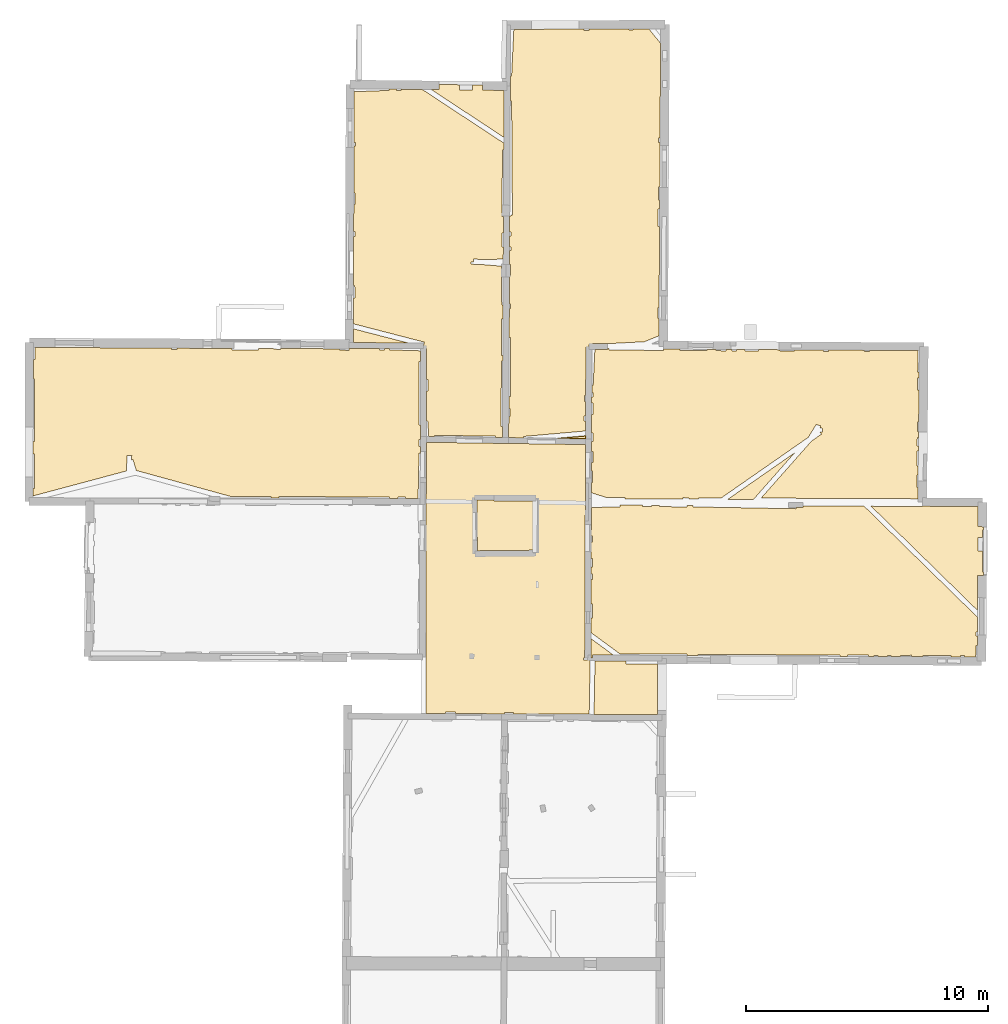
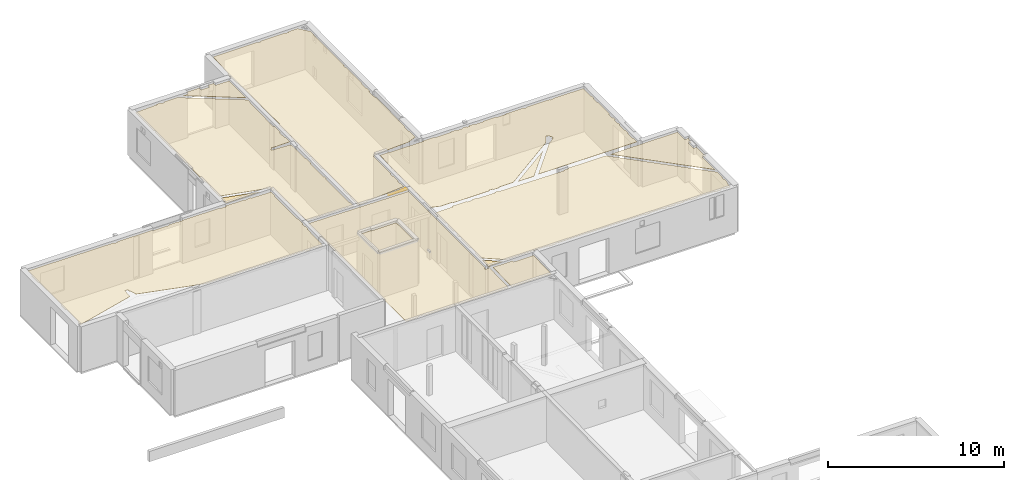
# One storey, part 13 of 17: 14 coverings.
"""IFC2X3 building model written with IfcOpenShell, lengths in metres."""

from ifc_helpers import new_model, entity, si_unit, converted_unit, derived_unit, direction, frame, origin, origin_with_axes, place, context, subcontext, project, spatial, polyline, outline, extrude, material, layer, layer_set, layer_usage, type_object, element, save


model = new_model("IFC2X3")

# Units and contexts
model_context = context("Model", 3, precision=1e-05, world=origin(), true_north=direction((0.0, 1.0)))
body_context = subcontext(model_context, "Body", "Model", "MODEL_VIEW")
ifc_project = project(units=[si_unit("LENGTHUNIT", "METRE"), si_unit("AREAUNIT", "SQUARE_METRE"), si_unit("VOLUMEUNIT", "CUBIC_METRE"), converted_unit("PLANEANGLEUNIT", "DEGREE", entity("IfcRatioMeasure", 0.0174532925199433), si_unit("PLANEANGLEUNIT", "RADIAN"), dimensions=[0, 0, 0, 0, 0, 0, 0]), si_unit("MASSUNIT", "GRAM", prefix="KILO"), derived_unit("MASSDENSITYUNIT", [(si_unit("MASSUNIT", "GRAM", prefix="KILO"), 1), (si_unit("LENGTHUNIT", "METRE"), -3)]), derived_unit("MOMENTOFINERTIAUNIT", [(si_unit("LENGTHUNIT", "METRE"), 4)]), si_unit("TIMEUNIT", "SECOND"), si_unit("FREQUENCYUNIT", "HERTZ"), si_unit("THERMODYNAMICTEMPERATUREUNIT", "DEGREE_CELSIUS"), derived_unit("THERMALTRANSMITTANCEUNIT", [(si_unit("MASSUNIT", "GRAM", prefix="KILO"), 1), (si_unit("THERMODYNAMICTEMPERATUREUNIT", "KELVIN"), -1), (si_unit("TIMEUNIT", "SECOND"), -3)]), derived_unit("VOLUMETRICFLOWRATEUNIT", [(si_unit("LENGTHUNIT", "METRE"), 3), (si_unit("TIMEUNIT", "SECOND"), -1)]), si_unit("ELECTRICCURRENTUNIT", "AMPERE"), si_unit("ELECTRICVOLTAGEUNIT", "VOLT"), si_unit("POWERUNIT", "WATT"), si_unit("FORCEUNIT", "NEWTON", prefix="KILO"), si_unit("ILLUMINANCEUNIT", "LUX"), si_unit("LUMINOUSFLUXUNIT", "LUMEN"), si_unit("LUMINOUSINTENSITYUNIT", "CANDELA"), derived_unit("USERDEFINED", [(si_unit("MASSUNIT", "GRAM", prefix="KILO"), -1), (si_unit("LENGTHUNIT", "METRE"), -2), (si_unit("TIMEUNIT", "SECOND"), 3), (si_unit("LUMINOUSFLUXUNIT", "LUMEN"), 1)]), derived_unit("LINEARVELOCITYUNIT", [(si_unit("LENGTHUNIT", "METRE"), 1), (si_unit("TIMEUNIT", "SECOND"), -1)]), si_unit("PRESSUREUNIT", "PASCAL"), derived_unit("USERDEFINED", [(si_unit("LENGTHUNIT", "METRE"), -2), (si_unit("MASSUNIT", "GRAM", prefix="KILO"), 1), (si_unit("TIMEUNIT", "SECOND"), -2)]), derived_unit("LINEARFORCEUNIT", [(si_unit("MASSUNIT", "GRAM", prefix="KILO"), 1), (si_unit("LENGTHUNIT", "METRE"), 1), (si_unit("TIMEUNIT", "SECOND"), -2), (si_unit("LENGTHUNIT", "METRE"), -1)]), derived_unit("PLANARFORCEUNIT", [(si_unit("MASSUNIT", "GRAM", prefix="KILO"), 1), (si_unit("LENGTHUNIT", "METRE"), 1), (si_unit("TIMEUNIT", "SECOND"), -2), (si_unit("LENGTHUNIT", "METRE"), -2)])], contexts=[model_context])

# Site, building, storey
placement = place(None, origin())
site = spatial("IfcSite", under=ifc_project, at=placement, CompositionType="ELEMENT")
building = spatial("IfcBuilding", under=site, at=placement, CompositionType="ELEMENT")
storey_placement = place(placement, frame((0.0, 0.0, 5.56662893295288)))
storey = spatial("IfcBuildingStorey", under=building, at=storey_placement, Name="Level 3", CompositionType="ELEMENT", Elevation=5.56662893295288)

# Coverings
ifc_material = material(Name="Covering default")
ifc_layer_1 = layer(ifc_material, 0.02)
ifc_layer_set_1 = layer_set([ifc_layer_1], Name="Covering : 20mm")
ifc_layer_usage_1 = layer_usage(ifc_layer_set_1, "AXIS3", "POSITIVE", 0.0)
covering_type_1 = type_object("IfcCoveringType", Name="Covering : 20mm", PredefinedType="CEILING")
covering_1_placement = place(placement, frame((0.0, 0.0, 8.5707950592041)))
element("IfcCovering", 1, at=covering_1_placement, inside=storey, type_object=covering_type_1, material=ifc_layer_usage_1, Name="Covering : 20mm", ObjectType="Covering : 20mm", PredefinedType="CEILING", context=body_context, shape_type="SweptSolid", body=[
    extrude(outline(polyline([(10.0566816329956, 51.0667304992676), (11.3422231674194, 51.0576782226562), (11.3391790390015, 50.938289642334), (12.6407995223999, 50.929615020752), (12.6304807662964, 48.8446731567383), (10.0157308578491, 48.8572540283203), (10.0566816329956, 51.0667304992676)])), origin_with_axes(), (0.0, 0.0, 1.0), 0.02),
])
ifc_layer_2 = layer(ifc_material, 0.02)
ifc_layer_set_2 = layer_set([ifc_layer_2], Name="Covering : 20mm")
ifc_layer_usage_2 = layer_usage(ifc_layer_set_2, "AXIS3", "POSITIVE", 0.0)
covering_type_2 = type_object("IfcCoveringType", Name="Covering : 20mm", PredefinedType="CEILING")
covering_2_placement = place(placement, frame((0.0, 0.0, 8.5707950592041)))
element("IfcCovering", 2, at=covering_2_placement, inside=storey, type_object=covering_type_2, material=ifc_layer_usage_2, Name="Covering : 20mm", ObjectType="Covering : 20mm", PredefinedType="CEILING", context=body_context, shape_type="SweptSolid", body=[
    extrude(outline(polyline([(3.0847635269165, 56.8529739379883), (3.07373332977295, 56.8530120849609), (3.09631061553955, 58.4253082275391), (3.0901460647583, 58.4253959655762), (3.09582424163818, 60.0840721130371), (6.49047565460205, 60.0369300842285), (9.664381980896, 59.992847442627), (9.63185787200928, 51.1893882751465), (9.5756368637085, 51.1893615722656), (9.57567882537842, 51.1068153381348), (9.77567958831787, 51.1069183349609), (9.77563762664795, 51.1887741088867), (9.85890483856201, 51.1884651184082), (9.81571292877197, 48.8582191467285), (6.68682384490967, 48.8732719421387), (6.68679714202881, 48.9253349304199), (6.31291103363037, 48.9251441955566), (6.31293773651123, 48.875072479248), (4.2968168258667, 48.8847732543945), (4.29678630828857, 48.9441108703613), (3.88678646087646, 48.9439010620117), (3.88681507110596, 48.8867454528809), (3.07681560516357, 48.8906440734863), (3.0847635269165, 56.8529739379883)])), origin_with_axes(), (0.0, 0.0, 1.0), 0.02),
])
ifc_layer_3 = layer(ifc_material, 0.02)
ifc_layer_set_3 = layer_set([ifc_layer_3], Name="Covering : 20mm")
ifc_layer_usage_3 = layer_usage(ifc_layer_set_3, "AXIS3", "POSITIVE", 0.0)
covering_type_3 = type_object("IfcCoveringType", Name="Covering : 20mm", PredefinedType="CEILING")
covering_3_placement = place(placement, frame((0.0, 0.0, 8.5707950592041)))
element("IfcCovering", 3, at=covering_3_placement, inside=storey, type_object=covering_type_3, material=ifc_layer_usage_3, Name="Covering : 20mm", ObjectType="Covering : 20mm", PredefinedType="CEILING", context=body_context, shape_type="SweptSolid", body=[
    extrude(outline(polyline([(9.88479137420654, 51.983211517334), (10.8140344619751, 51.3014030456543), (9.95974636077881, 51.3074188232422), (9.95890140533447, 51.1874160766602), (9.88185596466064, 51.1888465881348), (9.88479137420654, 51.983211517334)])), origin_with_axes(), (0.0, 0.0, 1.0), 0.02),
])
ifc_layer_4 = layer(ifc_material, 0.02)
ifc_layer_set_4 = layer_set([ifc_layer_4], Name="Covering : 20mm")
ifc_layer_usage_4 = layer_usage(ifc_layer_set_4, "AXIS3", "POSITIVE", 0.0)
covering_type_4 = type_object("IfcCoveringType", Name="Covering : 20mm", PredefinedType="CEILING")
covering_4_placement = place(placement, frame((0.0, 0.0, 8.5707950592041)))
element("IfcCovering", 4, at=covering_4_placement, inside=storey, type_object=covering_type_4, material=ifc_layer_usage_4, Name="Covering : 20mm", ObjectType="Covering : 20mm", PredefinedType="CEILING", context=body_context, shape_type="SweptSolid", body=[
    extrude(outline(polyline([(11.0877733230591, 51.3486137390137), (13.8555593490601, 51.3390045166016), (13.8553590774536, 51.2813262939453), (14.3053350448608, 51.2790908813477), (14.3055658340454, 51.3292388916016), (20.1655807495117, 51.3022384643555), (20.165340423584, 51.2499618530273), (20.4756088256836, 51.248420715332), (20.4755821228027, 51.3023986816406), (21.3555793762207, 51.302848815918), (21.3556098937988, 51.2440452575684), (21.575611114502, 51.2429542541504), (21.5755844116211, 51.2929611206055), (21.7355842590332, 51.2930450439453), (21.7356109619141, 51.2421569824219), (22.1256103515625, 51.2402191162109), (22.1255836486816, 51.2932434082031), (22.285587310791, 51.293327331543), (22.2856140136719, 51.2394256591797), (22.6756134033203, 51.2374877929688), (22.6755867004395, 51.2935256958008), (23.1255874633789, 51.2937545776367), (23.125617980957, 51.2352485656738), (23.5956192016602, 51.2329139709473), (23.5955924987793, 51.2839965820312), (24.7555923461914, 51.2845916748047), (24.7556228637695, 51.2271461486816), (25.1421165466309, 51.225227355957), (25.1455917358398, 51.2847900390625), (25.3155975341797, 51.2748756408691), (25.3126525878906, 51.2243804931641), (25.7725677490234, 51.2220916748047), (25.7853775024414, 51.7051162719727), (25.8368034362793, 51.7037506103516), (25.8388977050781, 52.0851440429688), (25.7851829528809, 52.0851173400879), (25.7850952148438, 52.2551193237305), (25.8398323059082, 52.2551460266113), (25.8432006835938, 52.8678855895996), (21.1674766540527, 57.4466247558594), (18.6446723937988, 57.4576187133789), (18.6452445983887, 57.4021492004395), (18.3635444641113, 57.3992385864258), (18.3624877929688, 57.3413162231445), (14.1024465560913, 57.4191360473633), (14.1035108566284, 57.4774055480957), (13.8629369735718, 57.4784545898438), (13.8624467849731, 57.4190139770508), (12.7224416732788, 57.4284286499023), (12.7228956222534, 57.4834213256836), (12.3924150466919, 57.48486328125), (12.3924436569214, 57.4282608032227), (12.0224409103394, 57.4280700683594), (12.0224103927612, 57.4864768981934), (11.0794095993042, 57.4905853271484), (11.0807218551636, 57.4169769287109), (9.90478992462158, 57.3959808349609), (9.90043354034424, 56.216983795166), (9.95306301116943, 56.2170104980469), (9.9531888961792, 55.9670104980469), (9.89951038360596, 55.966983795166), (9.89703464508057, 55.2969779968262), (9.95353221893311, 55.2970085144043), (9.95372295379639, 54.9270095825195), (9.89566707611084, 54.9269790649414), (9.89467906951904, 54.6594429016113), (9.95386028289795, 54.6570091247559), (9.94398403167725, 54.4170036315918), (9.89379024505615, 54.4190711975098), (9.89008808135986, 53.4169769287109), (9.94449520111084, 53.4170036315918), (9.94479274749756, 52.8370056152344), (9.88794422149658, 52.8369750976562), (9.88570499420166, 52.2306022644043), (11.0877733230591, 51.3486137390137)])), origin_with_axes(), (0.0, 0.0, 1.0), 0.02),
])
ifc_layer_5 = layer(ifc_material, 0.02)
ifc_layer_set_5 = layer_set([ifc_layer_5], Name="Covering : 20mm")
ifc_layer_usage_5 = layer_usage(ifc_layer_set_5, "AXIS3", "POSITIVE", 0.0)
covering_type_5 = type_object("IfcCoveringType", Name="Covering : 20mm", PredefinedType="CEILING")
covering_5_placement = place(placement, frame((0.0, 0.0, 8.5707950592041)))
element("IfcCovering", 5, at=covering_5_placement, inside=storey, type_object=covering_type_5, material=ifc_layer_usage_5, Name="Covering : 20mm", ObjectType="Covering : 20mm", PredefinedType="CEILING", context=body_context, shape_type="SweptSolid", body=[
    extrude(outline(polyline([(25.8447341918945, 53.1463088989258), (25.8526496887207, 54.5864448547363), (26.1007232666016, 54.5850830078125), (26.1006546020508, 54.7347297668457), (26.0621070861816, 54.7347640991211), (26.0628929138184, 55.5918464660645), (25.8605079650879, 55.5935134887695), (25.8651695251465, 56.1584968566895), (26.0634117126465, 56.1568641662598), (26.0637016296387, 56.4745063781738), (26.0998573303223, 56.4744720458984), (26.0998001098633, 56.5983505249023), (25.8637199401855, 56.5996475219727), (25.8683204650879, 57.43603515625), (23.570182800293, 57.4464492797852), (23.5701370239258, 57.4361572265625), (21.4546089172363, 57.4453773498535), (25.8447341918945, 53.1463088989258)])), origin_with_axes(), (0.0, 0.0, 1.0), 0.02),
])
ifc_layer_6 = layer(ifc_material, 0.02)
ifc_layer_set_6 = layer_set([ifc_layer_6], Name="Covering : 20mm")
ifc_layer_usage_6 = layer_usage(ifc_layer_set_6, "AXIS3", "POSITIVE", 0.0)
covering_type_6 = type_object("IfcCoveringType", Name="Covering : 20mm", PredefinedType="CEILING")
covering_6_placement = place(placement, frame((0.0, 0.0, 8.5707950592041)))
element("IfcCovering", 6, at=covering_6_placement, inside=storey, type_object=covering_type_6, material=ifc_layer_usage_6, Name="Covering : 20mm", ObjectType="Covering : 20mm", PredefinedType="CEILING", context=body_context, shape_type="SweptSolid", body=[
    extrude(outline(polyline([(5.19799327850342, 55.6067581176758), (7.49471187591553, 55.6301727294922), (7.49496936798096, 57.6632843017578), (5.87815380096436, 57.6574630737305), (5.8779878616333, 57.7037315368652), (5.18692111968994, 57.7003059387207), (5.19799327850342, 55.6067581176758)])), origin_with_axes(), (0.0, 0.0, 1.0), 0.02),
])
ifc_layer_7 = layer(ifc_material, 0.02)
ifc_layer_set_7 = layer_set([ifc_layer_7], Name="Covering : 20mm")
ifc_layer_usage_7 = layer_usage(ifc_layer_set_7, "AXIS3", "POSITIVE", 0.0)
covering_type_7 = type_object("IfcCoveringType", Name="Covering : 20mm", PredefinedType="CEILING")
covering_7_placement = place(placement, frame((0.0, 0.0, 8.5707950592041)))
element("IfcCovering", 7, at=covering_7_placement, inside=storey, type_object=covering_type_7, material=ifc_layer_usage_7, Name="Covering : 20mm", ObjectType="Covering : 20mm", PredefinedType="CEILING", context=body_context, shape_type="SweptSolid", body=[
    extrude(outline(polyline([(15.5382089614868, 57.7311592102051), (18.3001174926758, 59.6533737182617), (16.5976371765137, 57.7265434265137), (15.5382089614868, 57.7311592102051)])), origin_with_axes(), (0.0, 0.0, 1.0), 0.02),
])
ifc_layer_8 = layer(ifc_material, 0.02)
ifc_layer_set_8 = layer_set([ifc_layer_8], Name="Covering : 20mm")
ifc_layer_usage_8 = layer_usage(ifc_layer_set_8, "AXIS3", "POSITIVE", 0.0)
covering_type_8 = type_object("IfcCoveringType", Name="Covering : 20mm", PredefinedType="CEILING")
covering_8_placement = place(placement, frame((0.0, 0.0, 8.5707950592041)))
element("IfcCovering", 8, at=covering_8_placement, inside=storey, type_object=covering_type_8, material=ifc_layer_usage_8, Name="Covering : 20mm", ObjectType="Covering : 20mm", PredefinedType="CEILING", context=body_context, shape_type="SweptSolid", body=[
    extrude(outline(polyline([(9.90859889984131, 58.4269866943359), (9.96192836761475, 58.4270133972168), (9.96168422698975, 58.9070129394531), (9.91037273406982, 58.9069862365723), (9.91162776947021, 59.2469863891602), (9.971510887146, 59.2470169067383), (9.97127437591553, 59.7070159912109), (9.91332721710205, 59.7069854736328), (9.91481685638428, 60.1100158691406), (9.97106838226318, 60.1100463867188), (9.9708833694458, 60.4694137573242), (9.91614437103271, 60.4693870544434), (9.91898250579834, 61.2380828857422), (9.97049045562744, 61.2370147705078), (9.98025035858154, 61.7070236206055), (9.92072010040283, 61.7082595825195), (9.92163944244385, 61.9569931030273), (9.98012065887451, 61.9570236206055), (9.98002910614014, 62.1370239257812), (9.9223051071167, 62.1369934082031), (9.92342281341553, 62.439754486084), (9.97987651824951, 62.4370193481445), (10.0519819259644, 63.9256629943848), (10.5790815353394, 63.9258613586426), (10.5790700912476, 63.9574165344238), (10.6396322250366, 63.9570426940918), (10.6391286849976, 63.8973655700684), (12.8758516311646, 63.8784446716309), (12.8763189315796, 63.9337043762207), (13.5695676803589, 63.929615020752), (13.5691366195679, 63.8788642883301), (14.6791429519653, 63.8694343566895), (14.6795988082886, 63.9230613708496), (15.050368309021, 63.9208717346191), (15.0491437911987, 63.8696174621582), (15.4591474533081, 63.8598289489746), (15.4605474472046, 63.9184455871582), (15.7191190719604, 63.916919708252), (15.7191476821899, 63.8599662780762), (15.8991479873657, 63.8600578308105), (15.8991193771362, 63.9158592224121), (16.2391204833984, 63.9138526916504), (16.2391471862793, 63.8602333068848), (16.7991485595703, 63.8605155944824), (16.7991218566895, 63.9105415344238), (17.6891288757324, 63.9052925109863), (17.6891555786133, 63.8509712219238), (18.2891540527344, 63.8512840270996), (18.2891273498535, 63.9017448425293), (19.4791297912598, 63.8947257995605), (19.4791564941406, 63.8418922424316), (19.6891593933105, 63.8419990539551), (19.6891326904297, 63.893482208252), (21.189136505127, 63.8846244812012), (21.1891632080078, 63.8327674865723), (21.3891639709473, 63.8328666687012), (21.3891372680664, 63.8834495544434), (23.3911666870117, 63.8716239929199), (23.3795928955078, 62.9938850402832), (23.4385681152344, 62.993106842041), (23.4361381530762, 62.7439155578613), (23.3797225952148, 62.7438850402832), (23.3799743652344, 62.2538833618164), (23.4313659667969, 62.2539100646973), (23.4184074401855, 60.9239044189453), (23.360652923584, 60.9238739013672), (23.3608589172363, 60.5238761901855), (23.4145088195801, 60.5239028930664), (23.4120597839355, 60.2724418640137), (23.3609886169434, 60.2738761901855), (23.3511657714844, 59.9238700866699), (23.4086494445801, 59.9222564697266), (23.4067077636719, 59.7230033874512), (23.3512687683105, 59.7238693237305), (23.3415870666504, 59.1038665771484), (23.4006652832031, 59.1029434204102), (23.3971672058105, 58.7438926696777), (23.3417701721191, 58.7438659667969), (23.3420372009277, 58.2238693237305), (23.3921012878418, 58.2238960266113), (23.3875160217285, 57.7532272338867), (16.9131622314453, 57.7815971374512), (18.9932174682617, 60.1357536315918), (19.4039764404297, 60.421630859375), (19.3468475341797, 60.5037117004395), (19.4468421936035, 60.5027236938477), (19.4484481811523, 60.664909362793), (19.348461151123, 60.6658973693848), (19.3791084289551, 60.7610702514648), (19.1907043457031, 60.8217391967773), (18.8592491149902, 60.2861862182617), (15.2722539901733, 57.7897338867188), (14.3322591781616, 57.7892532348633), (14.3322858810425, 57.7364120483398), (13.9302473068237, 57.738166809082), (13.9322576522827, 57.7890472412109), (13.6822519302368, 57.7989196777344), (13.6798963546753, 57.7392578125), (11.2922773361206, 57.7496604919434), (11.2922468185425, 57.8076934814453), (10.5122480392456, 57.8072967529297), (9.9070405960083, 58.0050201416016), (9.90859889984131, 58.4269866943359)])), origin_with_axes(), (0.0, 0.0, 1.0), 0.02),
])
ifc_layer_9 = layer(ifc_material, 0.02)
ifc_layer_set_9 = layer_set([ifc_layer_9], Name="Covering : 20mm")
ifc_layer_usage_9 = layer_usage(ifc_layer_set_9, "AXIS3", "POSITIVE", 0.0)
covering_type_9 = type_object("IfcCoveringType", Name="Covering : 20mm", PredefinedType="CEILING")
covering_9_placement = place(placement, frame((0.0, 0.0, 8.5707950592041)))
element("IfcCovering", 9, at=covering_9_placement, inside=storey, type_object=covering_type_9, material=ifc_layer_usage_9, Name="Covering : 20mm", ObjectType="Covering : 20mm", PredefinedType="CEILING", context=body_context, shape_type="SweptSolid", body=[
    extrude(outline(polyline([(-13.1401662826538, 58.1855506896973), (-13.0879497528076, 58.1852111816406), (-13.0786762237549, 59.6052093505859), (-13.1370878219604, 59.6055908203125), (-13.1359615325928, 60.1251792907715), (-13.0789413452148, 60.1252098083496), (-13.0802631378174, 62.7052116394043), (-13.1303672790527, 62.7051849365234), (-13.1286554336548, 63.4951858520508), (-13.0706691741943, 63.4952163696289), (-13.0709285736084, 64.0033798217773), (-7.43091297149658, 63.971981048584), (-7.43088531494141, 63.9181098937988), (-7.19088363647461, 63.9182319641113), (-7.19091033935547, 63.970645904541), (-4.92090511322021, 63.9580039978027), (-4.92087554931641, 63.8993949890137), (-3.83087539672852, 63.8999519348145), (-3.83090496063232, 63.9572944641113), (-3.2100887298584, 63.9538993835449), (-3.2108907699585, 63.9302711486816), (-2.92088603973389, 63.9204216003418), (-2.91964721679688, 63.9568977355957), (-0.499568939208984, 63.9434394836426), (-0.500870704650879, 63.891658782959), (-0.0930042266845703, 63.881404876709), (-0.0909700393676758, 63.962345123291), (-0.091008186340332, 63.955394744873), (1.15909671783447, 63.954761505127), (1.15912342071533, 63.9025077819824), (1.36912441253662, 63.9026145935059), (1.36909770965576, 63.9546546936035), (1.57078456878662, 63.9545555114746), (1.56912517547607, 63.9027137756348), (2.85875415802002, 63.8614311218262), (2.857253074646, 63.4231567382812), (2.79937076568604, 63.4233474731445), (2.7907133102417, 60.803337097168), (2.84828472137451, 60.8031463623047), (2.8462438583374, 60.206901550293), (2.79101848602295, 60.2068748474121), (2.79117298126221, 59.9033393859863), (2.84520435333252, 59.9033660888672), (2.84427547454834, 59.632194519043), (2.7913122177124, 59.6333389282227), (2.75113010406494, 57.7720146179199), (2.24069404602051, 57.7728118896484), (2.24223804473877, 57.8230590820312), (1.92223262786865, 57.832893371582), (1.92040157318115, 57.7733154296875), (1.58213329315186, 57.7738418579102), (1.58223247528076, 57.8327217102051), (-2.98777198791504, 57.8403816223145), (-2.98787117004395, 57.7809829711914), (-3.31774139404297, 57.7814979553223), (-3.31777191162109, 57.8402099609375), (-4.94777202606201, 57.8393783569336), (-8.88172912597656, 58.9215126037598), (-9.01688098907471, 59.3743896484375), (-9.0719051361084, 59.357967376709), (-9.06836318969727, 59.5301666259766), (-9.26832103729248, 59.5342788696289), (-9.28132057189941, 58.9022674560547), (-13.1408462524414, 57.8719139099121), (-13.1401662826538, 58.1855506896973)])), origin_with_axes(), (0.0, 0.0, 1.0), 0.02),
])
ifc_layer_10 = layer(ifc_material, 0.02)
ifc_layer_set_10 = layer_set([ifc_layer_10], Name="Covering : 20mm")
ifc_layer_usage_10 = layer_usage(ifc_layer_set_10, "AXIS3", "POSITIVE", 0.0)
covering_type_10 = type_object("IfcCoveringType", Name="Covering : 20mm", PredefinedType="CEILING")
covering_10_placement = place(placement, frame((0.0, 0.0, 8.5707950592041)))
element("IfcCovering", 10, at=covering_10_placement, inside=storey, type_object=covering_type_10, material=ifc_layer_usage_10, Name="Covering : 20mm", ObjectType="Covering : 20mm", PredefinedType="CEILING", context=body_context, shape_type="SweptSolid", body=[
    extrude(outline(polyline([(8.50907039642334, 60.2489166259766), (9.66570377349854, 60.3508911132812), (9.66526889801025, 60.2328567504883), (8.50907039642334, 60.2489166259766)])), origin_with_axes(), (0.0, 0.0, 1.0), 0.02),
])
ifc_layer_11 = layer(ifc_material, 0.02)
ifc_layer_set_11 = layer_set([ifc_layer_11], Name="Covering : 20mm")
ifc_layer_usage_11 = layer_usage(ifc_layer_set_11, "AXIS3", "POSITIVE", 0.0)
covering_type_11 = type_object("IfcCoveringType", Name="Covering : 20mm", PredefinedType="CEILING")
covering_11_placement = place(placement, frame((0.0, 0.0, 8.5707950592041)))
element("IfcCovering", 11, at=covering_11_placement, inside=storey, type_object=covering_type_11, material=ifc_layer_usage_11, Name="Covering : 20mm", ObjectType="Covering : 20mm", PredefinedType="CEILING", context=body_context, shape_type="SweptSolid", body=[
    extrude(outline(polyline([(7.10599422454834, 60.2684020996094), (7.10095691680908, 60.3255462646484), (9.6664457321167, 60.5517311096191), (9.66794300079346, 60.9568634033203), (9.61063480377197, 60.9568328857422), (9.6105260848999, 61.1668319702148), (9.66871929168701, 61.166862487793), (9.67093563079834, 61.7668647766113), (9.62021923065186, 61.7668380737305), (9.62008571624756, 62.0268363952637), (9.67189693450928, 62.0268630981445), (9.6792459487915, 64.0163116455078), (9.80424404144287, 64.0158462524414), (9.79903697967529, 64.1157150268555), (9.95764446258545, 64.1239852905273), (9.95762920379639, 64.1656265258789), (10.5789880752563, 64.1658630371094), (10.5805788040161, 64.1674118041992), (10.7679738998413, 64.1662521362305), (12.0911149978638, 64.2352600097656), (12.6945161819458, 64.4810638427734), (12.6984853744507, 65.1884078979492), (12.6484670639038, 65.1883850097656), (12.6482305526733, 65.6483917236328), (12.7010660171509, 65.6484146118164), (12.7198629379272, 68.998420715332), (12.6665143966675, 68.9983978271484), (12.6661520004272, 69.7084045410156), (12.7238473892212, 69.7084350585938), (12.7259798049927, 70.0884323120117), (12.6759557723999, 70.0884094238281), (12.6756811141968, 70.6284027099609), (12.7290086746216, 70.6284255981445), (12.739333152771, 72.4684371948242), (12.6847372055054, 72.4684143066406), (12.684645652771, 72.6484069824219), (12.7403440475464, 72.6484375), (12.7622785568237, 76.5573654174805), (12.2775030136108, 77.1533813476562), (11.6323385238647, 77.1509704589844), (11.6323671340942, 77.0978698730469), (11.4623670578003, 77.0977783203125), (11.4623384475708, 77.1503372192383), (9.81233882904053, 77.144172668457), (9.81237125396729, 77.0869445800781), (9.59237194061279, 77.0868225097656), (9.59234142303467, 77.1433486938477), (6.70510387420654, 77.1325607299805), (6.61333560943604, 75.2052993774414), (6.55864810943604, 75.2079010009766), (6.55832004547119, 74.1649169921875), (6.61386775970459, 74.1652984619141), (6.64627742767334, 69.4653167724609), (6.5931921005249, 69.4649505615234), (6.59237957000732, 69.4190979003906), (6.53590869903564, 69.4200973510742), (6.53281497955322, 68.765266418457), (6.58663463592529, 68.7652893066406), (6.5867166519165, 68.6052856445312), (6.53205966949463, 68.6052551269531), (6.52993488311768, 68.1552581787109), (6.58694744110107, 68.1552886962891), (6.58702754974365, 67.9952850341797), (6.52917766571045, 67.9952545166016), (6.52651500701904, 67.4315185546875), (6.577317237854, 67.4315414428711), (6.57754993438721, 66.9752807617188), (6.52435970306396, 66.9752578735352), (6.51880168914795, 65.7985458374023), (6.57815456390381, 65.795280456543), (6.56824779510498, 65.6152725219727), (6.51794910430908, 65.6180419921875), (6.51226902008057, 64.4154815673828), (6.56886196136475, 64.4152755737305), (6.56010723114014, 61.9852676391602), (6.5007905960083, 61.985481262207), (6.49842929840088, 61.4852409362793), (6.55036449432373, 61.4852676391602), (6.55053234100342, 61.1552658081055), (6.49686908721924, 61.1552391052246), (6.49272060394287, 60.2769203186035), (7.10599422454834, 60.2684020996094)])), origin_with_axes(), (0.0, 0.0, 1.0), 0.02),
])
ifc_layer_12 = layer(ifc_material, 0.02)
ifc_layer_set_12 = layer_set([ifc_layer_12], Name="Covering : 20mm")
ifc_layer_usage_12 = layer_usage(ifc_layer_set_12, "AXIS3", "POSITIVE", 0.0)
covering_type_12 = type_object("IfcCoveringType", Name="Covering : 20mm", PredefinedType="CEILING")
covering_12_placement = place(placement, frame((0.0, 0.0, 8.5707950592041)))
element("IfcCovering", 12, at=covering_12_placement, inside=storey, type_object=covering_type_12, material=ifc_layer_usage_12, Name="Covering : 20mm", ObjectType="Covering : 20mm", PredefinedType="CEILING", context=body_context, shape_type="SweptSolid", body=[
    extrude(outline(polyline([(0.0858316421508789, 66.0419540405273), (0.138029098510742, 66.0419769287109), (0.137768745422363, 66.5519790649414), (0.0873966217041016, 66.5519561767578), (0.0888442993164062, 67.0238800048828), (0.0880403518676758, 67.0238800048828), (0.0949487686157227, 67.9830932617188), (0.0917882919311523, 67.9831161499023), (0.0936250686645508, 68.5819625854492), (0.146728515625, 68.5819854736328), (0.146620750427246, 68.7919921875), (0.0942697525024414, 68.7919692993164), (0.0976448059082031, 69.8919677734375), (0.15605640411377, 69.8919982910156), (0.155810356140137, 70.3719940185547), (0.0991172790527344, 70.3719635009766), (0.105069160461426, 72.3119659423828), (0.164816856384277, 72.3119964599609), (0.164734840393066, 72.4720001220703), (0.105560302734375, 72.4719696044922), (0.111967086791992, 74.5601119995117), (1.55363941192627, 74.6127090454102), (1.5516996383667, 74.665885925293), (1.85361194610596, 74.6626052856445), (1.85364437103271, 74.6028594970703), (2.05364513397217, 74.6029663085938), (2.05361461639404, 74.6604309082031), (2.92624950408936, 74.6509399414062), (6.29016399383545, 72.4386596679688), (6.28882312774658, 72.1547393798828), (6.23489665985107, 72.1551055908203), (6.21630764007568, 69.4050979614258), (6.27583408355713, 69.4046936035156), (6.27267169952393, 68.7351226806641), (6.21665096282959, 68.7350921630859), (6.21694850921631, 68.1550979614258), (6.26993083953857, 68.1551208496094), (6.26753330230713, 67.6473999023438), (5.35412883758545, 67.6284790039062), (5.04582500457764, 67.6549987792969), (5.03729724884033, 67.5558853149414), (5.03726482391357, 67.5349655151367), (4.93726444244385, 67.534912109375), (4.93730449676514, 67.4544372558594), (5.03713321685791, 67.4544830322266), (5.03710079193115, 67.4349594116211), (5.03907108306885, 67.4349594116211), (5.03934192657471, 67.4219131469727), (5.34762096405029, 67.4282989501953), (6.18679141998291, 67.3561096191406), (6.208176612854, 65.7550888061523), (6.25860118865967, 65.7564163208008), (6.25585269927979, 65.1747360229492), (6.19847393035889, 65.1750869750977), (6.18924617767334, 63.6650810241699), (6.2487211227417, 63.6647148132324), (6.24763584136963, 63.4348945617676), (6.18936443328857, 63.4350814819336), (6.18074703216553, 60.7350769042969), (6.23488140106201, 60.7349052429199), (6.2327356338501, 60.2805290222168), (5.95018100738525, 60.2844543457031), (5.95095348358154, 60.3349609375), (3.42093181610107, 60.3736610412598), (3.42010402679443, 60.3195915222168), (3.19440364837646, 60.3227272033691), (3.15062999725342, 60.9635238647461), (3.09882259368896, 60.9599838256836), (3.1030797958374, 62.203498840332), (3.15999507904053, 62.2035293579102), (3.15974903106689, 62.6835250854492), (3.10472202301025, 62.6834983825684), (3.10908222198486, 63.9570503234863), (2.9844217300415, 63.9574775695801), (2.98450565338135, 64.122200012207), (3.00968647003174, 64.2195816040039), (0.0825624465942383, 64.9764709472656), (0.0858316421508789, 66.0419540405273)])), origin_with_axes(), (0.0, 0.0, 1.0), 0.02),
])
ifc_layer_13 = layer(ifc_material, 0.02)
ifc_layer_set_13 = layer_set([ifc_layer_13], Name="Covering : 20mm")
ifc_layer_usage_13 = layer_usage(ifc_layer_set_13, "AXIS3", "POSITIVE", 0.0)
covering_type_13 = type_object("IfcCoveringType", Name="Covering : 20mm", PredefinedType="CEILING")
covering_13_placement = place(placement, frame((0.0, 0.0, 8.5707950592041)))
element("IfcCovering", 13, at=covering_13_placement, inside=storey, type_object=covering_type_13, material=ifc_layer_usage_13, Name="Covering : 20mm", ObjectType="Covering : 20mm", PredefinedType="CEILING", context=body_context, shape_type="SweptSolid", body=[
    extrude(outline(polyline([(0.0819292068481445, 64.7700500488281), (2.309006690979, 64.1941833496094), (0.0801658630371094, 64.1953048706055), (0.0819292068481445, 64.7700500488281)])), origin_with_axes(), (0.0, 0.0, 1.0), 0.02),
])
ifc_layer_14 = layer(ifc_material, 0.02)
ifc_layer_set_14 = layer_set([ifc_layer_14], Name="Covering : 20mm")
ifc_layer_usage_14 = layer_usage(ifc_layer_set_14, "AXIS3", "POSITIVE", 0.0)
covering_type_14 = type_object("IfcCoveringType", Name="Covering : 20mm", PredefinedType="CEILING")
covering_14_placement = place(placement, frame((0.0, 0.0, 8.5707950592041)))
element("IfcCovering", 14, at=covering_14_placement, inside=storey, type_object=covering_type_14, material=ifc_layer_usage_14, Name="Covering : 20mm", ObjectType="Covering : 20mm", PredefinedType="CEILING", context=body_context, shape_type="SweptSolid", body=[
    extrude(outline(polyline([(3.29634952545166, 74.6469192504883), (3.60752773284912, 74.6435317993164), (3.60978603363037, 74.8513031005859), (4.46283435821533, 74.8454742431641), (4.46049785614014, 74.6364135742188), (5.00046443939209, 74.6303787231445), (5.00282764434814, 74.8417892456055), (5.40942287445068, 74.8390197753906), (5.40708446502686, 74.6239929199219), (6.30044078826904, 74.6142807006836), (6.29129123687744, 72.6772918701172), (3.29634952545166, 74.6469192504883)])), origin_with_axes(), (0.0, 0.0, 1.0), 0.02),
])

save(model, "model.ifc")
